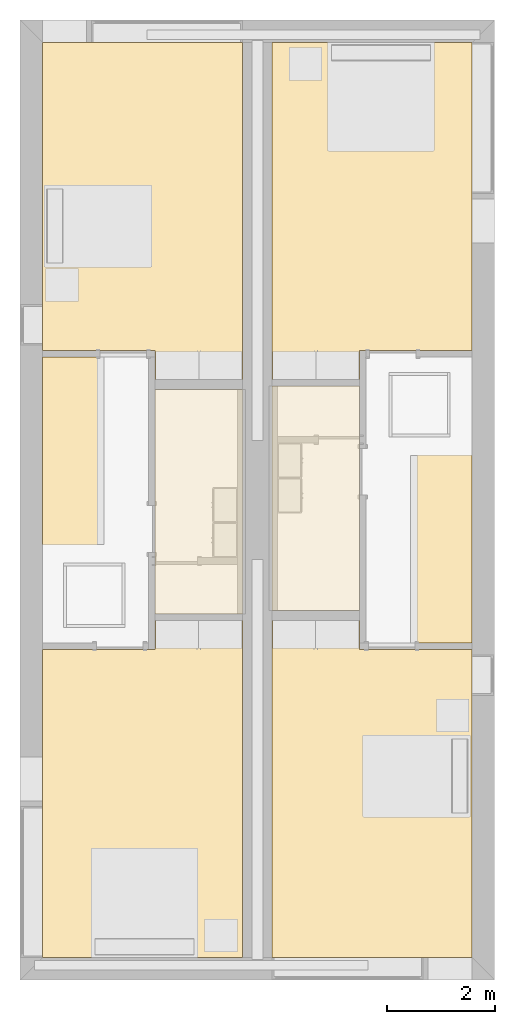
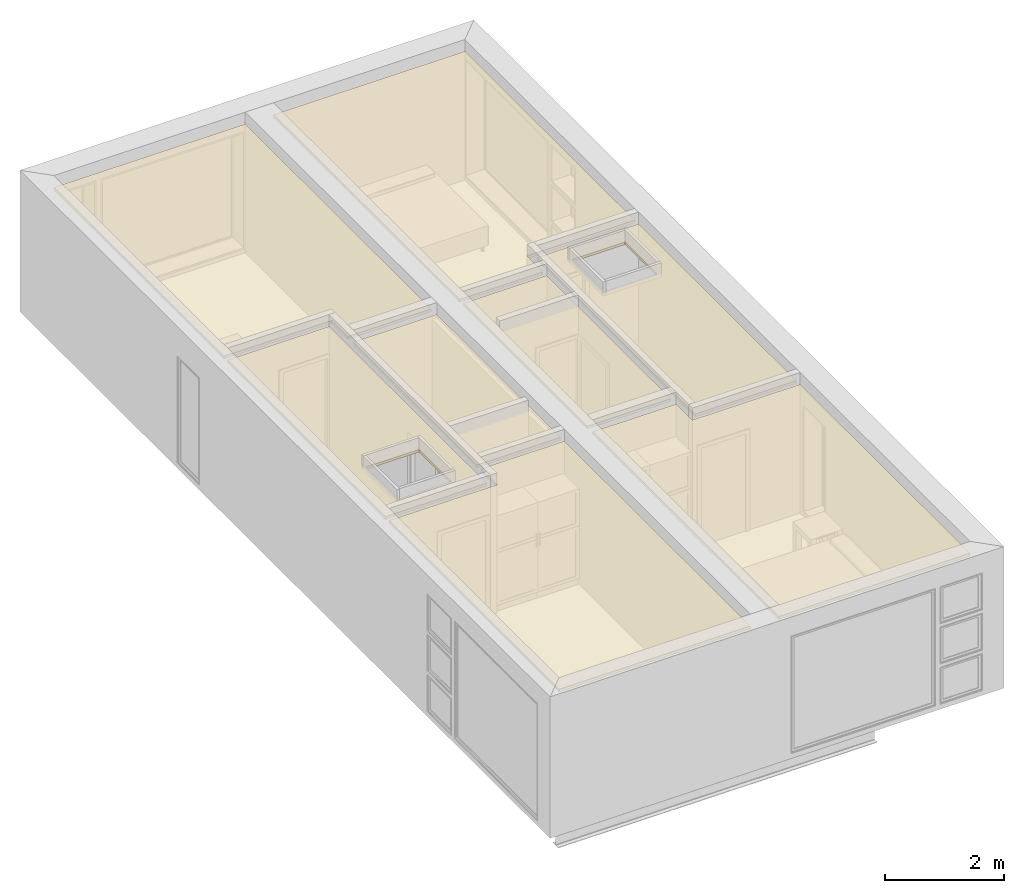
# One storey, part 6 of 10: 8 coverings.
"""IFC2X3 building model written with IfcOpenShell, lengths in metres."""

import ifcopenshell
import ifcopenshell.guid

model = None  # the IFC model being written
_history = None  # IfcOwnerHistory: only IFC2X3 demands one
_inside = {}  # id of a spatial element -> (the spatial element, [elements in it])
_under = {}  # id of a project, library or spatial element -> (it, [spatial elements below it])
_declared = {}  # id of a project -> (the project, [libraries it declares])
_typed = {}  # id of a type object -> (the type object, [elements of that type])
_made_of = {}  # id of a material, layer set ... -> (it, [elements and type objects made of it])


def new_model(schema):
    """Start an empty IFC model of exactly this schema.

    Asked for "IFC4X3", IfcOpenShell would pick the latest addendum, in which some entities
    have other attributes; the version numbers below select the first issue.
    IFC2X3 requires an IfcOwnerHistory on every rooted entity: one is made here for all.
    """
    global model, _history
    if schema == "IFC4X3":
        model = ifcopenshell.file(schema_version=(4, 3, 0, 0))
    else:
        model = ifcopenshell.file(schema=schema)
    _inside.clear()
    _under.clear()
    _declared.clear()
    _typed.clear()
    _made_of.clear()
    _history = None
    if model.schema == "IFC2X3":
        org = make("IfcOrganization", Name="unknown")
        user = make(
            "IfcPersonAndOrganization",
            ThePerson=make("IfcPerson", FamilyName="unknown"),
            TheOrganization=org,
        )
        app = make(
            "IfcApplication",
            ApplicationDeveloper=org,
            Version="unknown",
            ApplicationFullName="unknown",
            ApplicationIdentifier="unknown",
        )
        _history = make(
            "IfcOwnerHistory",
            OwningUser=user,
            OwningApplication=app,
            ChangeAction="ADDED",
            CreationDate=0,
        )
    return model


def make(cls, **values):
    """One entity of the class cls with the attributes given. An attribute that is None is left unset."""
    return model.create_entity(
        cls, **{name: value for name, value in values.items() if value is not None}
    )


def entity(cls, *values):
    """Any entity or typed value of the class cls, its attributes in the order of the schema. None: left unset."""
    e = model.create_entity(cls)
    for i, value in enumerate(values):
        if value is not None:
            e[i] = value
    return e


def rooted(cls, **values):
    """An entity with a GlobalId (a new one), such as an element, a storey or a relation."""
    return make(cls, GlobalId=ifcopenshell.guid.new(), OwnerHistory=_history, **values)


def si_unit(unit_type, name, prefix=None):
    """IfcSIUnit, for example si_unit("LENGTHUNIT", "METRE", prefix="MILLI")."""
    return make("IfcSIUnit", UnitType=unit_type, Prefix=prefix, Name=name)


def converted_unit(unit_type, name, factor, base, dimensions=None, offset=None):
    """IfcConversionBasedUnit, such as the inch: factor (a typed value) times the base unit."""
    return make(
        "IfcConversionBasedUnit"
        if offset is None
        else "IfcConversionBasedUnitWithOffset",
        ConversionOffset=offset,
        Dimensions=None
        if dimensions is None
        else entity("IfcDimensionalExponents", *dimensions),
        UnitType=unit_type,
        Name=name,
        ConversionFactor=make(
            "IfcMeasureWithUnit", ValueComponent=factor, UnitComponent=base
        ),
    )


def derived_unit(unit_type, elements):
    """IfcDerivedUnit: a product of units, each with its exponent."""
    return make(
        "IfcDerivedUnit",
        Elements=[
            make("IfcDerivedUnitElement", Unit=unit, Exponent=power)
            for unit, power in elements
        ],
        UnitType=unit_type,
    )


def assignment(units):
    """IfcUnitAssignment: the units of a project."""
    return None if units is None else make("IfcUnitAssignment", Units=units)


def point(xyz):
    """IfcCartesianPoint."""
    return None if xyz is None else make("IfcCartesianPoint", Coordinates=xyz)


def direction(xyz):
    """IfcDirection."""
    return None if xyz is None else make("IfcDirection", DirectionRatios=xyz)


def frame(location, z_axis=None, x_axis=None):
    """IfcAxis2Placement3D, a coordinate frame: its origin and axes. An axis left out is left unset."""
    return make(
        "IfcAxis2Placement3D",
        Location=point(location),
        Axis=direction(z_axis),
        RefDirection=direction(x_axis),
    )


def frame_2d(location, x_axis=None):
    """IfcAxis2Placement2D, a coordinate frame in the plane: its origin and x axis."""
    return make(
        "IfcAxis2Placement2D", Location=point(location), RefDirection=direction(x_axis)
    )


def origin():
    """The frame at (0, 0, 0) with its axes left unset."""
    return frame((0.0, 0.0, 0.0))


def place(relative_to, where):
    """IfcLocalPlacement: puts the frame where relative to a parent placement (None: the world)."""
    return make(
        "IfcLocalPlacement", PlacementRelTo=relative_to, RelativePlacement=where
    )


def context(
    kind, dimensions, precision=None, world=None, true_north=None, identifier=None
):
    """IfcGeometricRepresentationContext, for example the 3D "Model" context."""
    return make(
        "IfcGeometricRepresentationContext",
        ContextIdentifier=identifier,
        ContextType=kind,
        CoordinateSpaceDimension=dimensions,
        Precision=precision,
        WorldCoordinateSystem=world,
        TrueNorth=true_north,
    )


def subcontext(parent, identifier, kind, view, scale=None):
    """IfcGeometricRepresentationSubContext, for example "Body" below "Model"."""
    return make(
        "IfcGeometricRepresentationSubContext",
        ContextIdentifier=identifier,
        ContextType=kind,
        ParentContext=parent,
        TargetScale=scale,
        TargetView=view,
    )


def project(units=None, contexts=None):
    """IfcProject with its units and contexts."""
    return rooted(
        "IfcProject",
        Name="project",
        RepresentationContexts=contexts,
        UnitsInContext=assignment(units),
    )


def spatial(cls, under=None, at=None, **own):
    """A site, building, storey or space (cls), placed at a placement, below another one or the project."""
    s = rooted(cls, ObjectPlacement=at, **own)
    if under is not None:
        _under.setdefault(under.id(), (under, []))[1].append(s)
    return s


def polyline(points):
    """IfcPolyline through the points."""
    return make("IfcPolyline", Points=[point(p) for p in points])


def profile(cls, at=None, kind="AREA", **sizes):
    """A parametric profile (cls). Its sizes go by their IFC names, for example OverallWidth=200.0."""
    return make(cls, ProfileType=kind, Position=at, **sizes)


def rectangle(**sizes):
    """IfcRectangleProfileDef."""
    return profile("IfcRectangleProfileDef", **sizes)


def outline(outer, holes=None, kind="AREA"):
    """IfcArbitraryClosedProfileDef: a profile drawn as a closed curve; with holes, ...WithVoids."""
    if holes is None:
        return make("IfcArbitraryClosedProfileDef", ProfileType=kind, OuterCurve=outer)
    return make(
        "IfcArbitraryProfileDefWithVoids",
        ProfileType=kind,
        OuterCurve=outer,
        InnerCurves=holes,
    )


def extrude(swept, where, along, depth):
    """IfcExtrudedAreaSolid: the profile swept, set in the frame where, extruded along a direction by depth."""
    return make(
        "IfcExtrudedAreaSolid",
        SweptArea=swept,
        Position=where,
        ExtrudedDirection=direction(along),
        Depth=depth,
    )


def shape(context_of_items, identifier, shape_type, items):
    """IfcShapeRepresentation: the items that make up one representation, for example the "Body"."""
    return make(
        "IfcShapeRepresentation",
        ContextOfItems=context_of_items,
        RepresentationIdentifier=identifier,
        RepresentationType=shape_type,
        Items=items,
    )


def material(Name=None, Category=None):
    """IfcMaterial."""
    return make("IfcMaterial", Name=Name, Category=Category)


def layer(
    of_material, thickness, ventilated=None, Name=None, Category=None, Priority=None
):
    """IfcMaterialLayer: one layer of a wall or slab, of a material (None: an air gap)."""
    return make(
        "IfcMaterialLayer",
        Material=of_material,
        LayerThickness=thickness,
        IsVentilated=ventilated,
        Name=Name,
        Category=Category,
        Priority=Priority,
    )


def layer_set(layers, Name=None):
    """IfcMaterialLayerSet."""
    return make("IfcMaterialLayerSet", MaterialLayers=layers, LayerSetName=Name)


def layer_usage(for_layer_set, set_direction, sense, offset, extent=None):
    """IfcMaterialLayerSetUsage: how a layer set lies in its element."""
    return make(
        "IfcMaterialLayerSetUsage",
        ForLayerSet=for_layer_set,
        LayerSetDirection=set_direction,
        DirectionSense=sense,
        OffsetFromReferenceLine=offset,
        ReferenceExtent=extent,
    )


def made_of(thing, what):
    """Note that an element or type object is made of a material, layer set ...; save() writes the relation."""
    if what is not None:
        _made_of.setdefault(what.id(), (what, []))[1].append(thing)
    return thing


def element(
    cls,
    number,
    at=None,
    inside=None,
    cuts=None,
    type_object=None,
    material=None,
    context=None,
    identifier="Body",
    shape_type=None,
    held_by="IfcProductDefinitionShape",
    body=None,
    shapes=None,
    **own,
):
    """One element of the class cls, such as IfcWall. Its Tag is "e" and its number.

    at: its placement. inside: the storey or other place that contains it. cuts: it is an
    opening in that element (IfcRelVoidsElement). A single representation is given by context,
    identifier, shape_type and body (its items); several are given by shapes. held_by: the class
    of the entity that holds the representations. save() writes the other relations.
    """
    e = rooted(cls, Tag="e%d" % number, ObjectPlacement=at, **own)
    if body is not None:
        shapes = [shape(context, identifier, shape_type, body)]
    if shapes is not None:
        e.Representation = make(held_by, Representations=shapes)
    if inside is not None:
        _inside.setdefault(inside.id(), (inside, []))[1].append(e)
    if cuts is not None:
        rooted(
            "IfcRelVoidsElement", RelatingBuildingElement=cuts, RelatedOpeningElement=e
        )
    if type_object is not None:
        _typed.setdefault(type_object.id(), (type_object, []))[1].append(e)
    return made_of(e, material)


def aggregate(whole, parts):
    """IfcRelAggregates: a whole, such as a stair, and the parts it consists of."""
    return rooted("IfcRelAggregates", RelatingObject=whole, RelatedObjects=parts)


def save(model, path):
    """Write the relations noted so far, then the file.

    IfcRelAggregates (storeys below a building ...), IfcRelContainedInSpatialStructure (elements
    in a storey), IfcRelDefinesByType, IfcRelAssociatesMaterial and IfcRelDeclares: one each for
    every whole, place, type object, material and project.
    """
    for whole, parts in _under.values():
        aggregate(whole, parts)
    for where, things in _inside.values():
        rooted(
            "IfcRelContainedInSpatialStructure",
            RelatedElements=things,
            RelatingStructure=where,
        )
    for kind, things in _typed.values():
        rooted("IfcRelDefinesByType", RelatedObjects=things, RelatingType=kind)
    for what, things in _made_of.values():
        rooted("IfcRelAssociatesMaterial", RelatedObjects=things, RelatingMaterial=what)
    for by, libraries in _declared.values():
        rooted("IfcRelDeclares", RelatingContext=by, RelatedDefinitions=libraries)
    model.write(path)


model = new_model("IFC2X3")

# Units and contexts
model_context = context("Model", 3, precision=1e-05, world=origin(), true_north=direction((6.12303176911189e-17, 1.0)))
body_context = subcontext(model_context, "Body", "Model", "MODEL_VIEW")
ifc_project = project(units=[derived_unit("USERDEFINED", [(si_unit("LENGTHUNIT", "METRE"), -2), (si_unit("TIMEUNIT", "SECOND"), -2), (si_unit("MASSUNIT", "GRAM", prefix="KILO"), 1)]), si_unit("FREQUENCYUNIT", "HERTZ"), si_unit("LENGTHUNIT", "METRE"), si_unit("ILLUMINANCEUNIT", "LUX"), derived_unit("LINEARVELOCITYUNIT", [(si_unit("TIMEUNIT", "SECOND"), -1), (si_unit("LENGTHUNIT", "METRE"), 1)]), si_unit("POWERUNIT", "WATT"), si_unit("LUMINOUSINTENSITYUNIT", "CANDELA"), si_unit("AREAUNIT", "SQUARE_METRE"), si_unit("VOLUMEUNIT", "CUBIC_METRE"), si_unit("ELECTRICVOLTAGEUNIT", "VOLT"), si_unit("PRESSUREUNIT", "PASCAL"), converted_unit("PLANEANGLEUNIT", "DEGREE", entity("IfcRatioMeasure", 0.0174532925199433), si_unit("PLANEANGLEUNIT", "RADIAN"), dimensions=[0, 0, 0, 0, 0, 0, 0]), si_unit("THERMODYNAMICTEMPERATUREUNIT", "DEGREE_CELSIUS"), si_unit("MASSUNIT", "GRAM", prefix="KILO"), derived_unit("VOLUMETRICFLOWRATEUNIT", [(si_unit("LENGTHUNIT", "METRE"), 3), (si_unit("TIMEUNIT", "SECOND"), -1)]), si_unit("TIMEUNIT", "SECOND"), si_unit("LUMINOUSFLUXUNIT", "LUMEN"), derived_unit("USERDEFINED", [(si_unit("LUMINOUSFLUXUNIT", "LUMEN"), 1), (si_unit("TIMEUNIT", "SECOND"), 3), (si_unit("MASSUNIT", "GRAM", prefix="KILO"), -1), (si_unit("LENGTHUNIT", "METRE"), -2)]), si_unit("FORCEUNIT", "NEWTON", prefix="KILO"), si_unit("ELECTRICCURRENTUNIT", "AMPERE"), derived_unit("THERMALTRANSMITTANCEUNIT", [(si_unit("TIMEUNIT", "SECOND"), -3), (si_unit("THERMODYNAMICTEMPERATUREUNIT", "KELVIN"), -1), (si_unit("MASSUNIT", "GRAM", prefix="KILO"), 1)])], contexts=[model_context])

# Site, building, storey, space
site_placement = place(None, origin())
site = spatial("IfcSite", under=ifc_project, at=site_placement, CompositionType="ELEMENT")
building_placement = place(site_placement, origin())
building = spatial("IfcBuilding", under=site, at=building_placement, CompositionType="ELEMENT")
storey_placement = place(building_placement, frame((0.0, 0.0, 3.10000000000038)))
storey = spatial("IfcBuildingStorey", under=building, at=storey_placement, Name="Level 2", CompositionType="ELEMENT", Elevation=3.10000000000038)
space_1_placement = place(storey_placement, origin())
space_1 = spatial("IfcSpace", under=storey, at=space_1_placement, CompositionType="ELEMENT", InteriorOrExteriorSpace="INTERNAL")

# Covering
ifc_material_1 = material(Name="Metal - Stud Layer")
ifc_layer_1 = layer(ifc_material_1, 0.045)
ifc_material_2 = material(Name="Plasterboard")
ifc_layer_2 = layer(ifc_material_2, 0.012)
ifc_layer_set = layer_set([ifc_layer_1, ifc_layer_2])
ifc_layer_usage_1 = layer_usage(ifc_layer_set, "AXIS3", "NEGATIVE", 0.0)
covering_1_placement = place(space_1_placement, origin())
element("IfcCovering", 1, at=covering_1_placement, inside=space_1, material=ifc_layer_usage_1, PredefinedType="CEILING", context=body_context, shape_type="SweptSolid", body=[
    extrude(outline(polyline([(-1.77566666666665, -3.986), (1.93233333333335, -3.986), (1.93233333333333, 1.723), (-0.156666666666675, 1.723), (-0.156666666666676, 2.263), (-1.77566666666667, 2.263), (-1.77566666666665, -3.986)])), frame((2.34933333333333, -4.40300000000001, 2.59999999999982), z_axis=(0.0, 0.0, 1.0), x_axis=(-1.0, 0.0, 0.0)), (0.0, 0.0, 1.0), 0.057),
])

# Space
space_2_placement = place(storey_placement, origin())
space_2 = spatial("IfcSpace", under=storey, at=space_2_placement, CompositionType="ELEMENT", InteriorOrExteriorSpace="INTERNAL")

# Coverings
ifc_layer_usage_2 = layer_usage(ifc_layer_set, "AXIS3", "NEGATIVE", 0.0)
covering_2_placement = place(space_2_placement, origin())
element("IfcCovering", 2, at=covering_2_placement, inside=space_2, material=ifc_layer_usage_2, PredefinedType="CEILING", context=body_context, shape_type="SweptSolid", body=[
    extrude(outline(polyline([(-2.263, -0.156666666666654), (-2.263, -1.77566666666667), (3.98599999999999, -1.77566666666667), (3.98599999999999, 1.93233333333333), (-1.72299999999999, 1.93233333333333), (-1.72299999999999, -0.156666666666654), (-2.263, -0.156666666666654)])), frame((6.45066666666667, -4.40300000000001, 2.59999999999982), z_axis=(0.0, 0.0, -1.0), x_axis=(0.0, 1.0, 0.0)), (0.0, 0.0, -1.0), 0.057),
])
ifc_layer_usage_3 = layer_usage(ifc_layer_set, "AXIS3", "NEGATIVE", 0.0)
covering_3_placement = place(storey_placement, origin())
element("IfcCovering", 3, at=covering_3_placement, inside=storey, material=ifc_layer_usage_3, PredefinedType="CEILING", context=body_context, shape_type="SweptSolid", body=[
    extrude(rectangle(XDim=1.61900000000002, YDim=4.16, at=frame_2d((-2.77555756156289e-16, -4.44089209850063e-16), x_axis=(1.0, 0.0))), frame((5.4845, -8.87000000000001, 2.59999999999982)), (0.0, 0.0, 1.0), 0.057),
])
ifc_layer_usage_4 = layer_usage(ifc_layer_set, "AXIS3", "NEGATIVE", 0.0)
covering_4_placement = place(storey_placement, origin())
element("IfcCovering", 4, at=covering_4_placement, inside=storey, material=ifc_layer_usage_4, PredefinedType="CEILING", context=body_context, shape_type="SweptSolid", body=[
    extrude(outline(polyline([(-0.982499999999988, -2.65), (0.982499999999994, -2.65), (0.982499999999986, 2.65), (-0.982499999999995, 2.65), (-0.982499999999988, -2.65)]), holes=[polyline([(-0.523050000000028, -2.30554999999995), (-0.523050000000032, -1.22444999999999), (0.506049999999968, -1.22444999999999), (0.506049999999972, -2.30554999999995), (-0.523050000000028, -2.30554999999995)])]), frame((7.40049999999999, -8.9, 2.6), z_axis=(0.0, 0.0, 1.0), x_axis=(-1.0, 0.0, 0.0)), (0.0, 0.0, 1.0), 0.057),
])
ifc_layer_usage_5 = layer_usage(ifc_layer_set, "AXIS3", "NEGATIVE", 0.0)
covering_5_placement = place(storey_placement, origin())
element("IfcCovering", 5, at=covering_5_placement, inside=storey, material=ifc_layer_usage_5, PredefinedType="CEILING", context=body_context, shape_type="SweptSolid", body=[
    extrude(rectangle(XDim=1.61899999999999, YDim=4.15999999999999, at=frame_2d((0.0, 6.66133814775094e-16), x_axis=(1.0, 0.0))), frame((3.31549999999999, -8.93, 2.59999999999982), z_axis=(0.0, 0.0, 1.0), x_axis=(-1.0, 0.0, 0.0)), (0.0, 0.0, 1.0), 0.057),
])
ifc_layer_usage_6 = layer_usage(ifc_layer_set, "AXIS3", "NEGATIVE", 0.0)
covering_6_placement = place(storey_placement, origin())
element("IfcCovering", 6, at=covering_6_placement, inside=storey, material=ifc_layer_usage_6, PredefinedType="CEILING", context=body_context, shape_type="SweptSolid", body=[
    extrude(outline(polyline([(-0.982499999999989, -2.65), (0.982500000000003, -2.65), (0.982499999999994, 2.65), (-0.982500000000007, 2.65), (-0.982499999999989, -2.65)]), holes=[polyline([(0.491050000000031, -1.22445000000003), (0.491050000000034, -2.30554999999999), (-0.538049999999965, -2.30555), (-0.538049999999968, -1.22445000000004), (0.491050000000031, -1.22445000000003)])]), frame((1.3995, -8.9, 2.6)), (0.0, 0.0, 1.0), 0.057),
])

# Space
space_3_placement = place(storey_placement, origin())
space_3 = spatial("IfcSpace", under=storey, at=space_3_placement, CompositionType="ELEMENT", InteriorOrExteriorSpace="INTERNAL")

# Covering
ifc_layer_usage_7 = layer_usage(ifc_layer_set, "AXIS3", "NEGATIVE", 0.0)
covering_7_placement = place(space_3_placement, origin())
element("IfcCovering", 7, at=covering_7_placement, inside=space_3, material=ifc_layer_usage_7, PredefinedType="CEILING", context=body_context, shape_type="SweptSolid", body=[
    extrude(outline(polyline([(-2.26299999999999, -0.156666666666665), (-2.26299999999999, -1.77566666666665), (3.98599999999999, -1.77566666666666), (3.98599999999999, 1.93233333333332), (-1.72299999999999, 1.93233333333333), (-1.72299999999999, -0.156666666666665), (-2.26299999999999, -0.156666666666665)])), frame((2.34933333333332, -13.397, 2.59999999999982), z_axis=(0.0, 0.0, -1.0), x_axis=(0.0, -1.0, 0.0)), (0.0, 0.0, -1.0), 0.057),
])

# Space
space_4_placement = place(storey_placement, origin())
space_4 = spatial("IfcSpace", under=storey, at=space_4_placement, CompositionType="ELEMENT", InteriorOrExteriorSpace="INTERNAL")

# Covering
ifc_layer_usage_8 = layer_usage(ifc_layer_set, "AXIS3", "NEGATIVE", 0.0)
covering_8_placement = place(space_4_placement, origin())
element("IfcCovering", 8, at=covering_8_placement, inside=space_4, material=ifc_layer_usage_8, PredefinedType="CEILING", context=body_context, shape_type="SweptSolid", body=[
    extrude(outline(polyline([(-1.77566666666666, -3.98599999999999), (1.93233333333334, -3.98599999999999), (1.93233333333333, 1.72300000000001), (-0.156666666666657, 1.72300000000001), (-0.156666666666657, 2.26299999999999), (-1.77566666666668, 2.26299999999999), (-1.77566666666666, -3.98599999999999)])), frame((6.45066666666665, -13.397, 2.59999999999982)), (0.0, 0.0, 1.0), 0.057),
])

save(model, "model.ifc")
